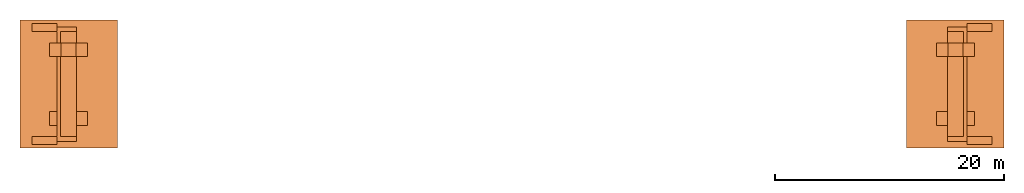
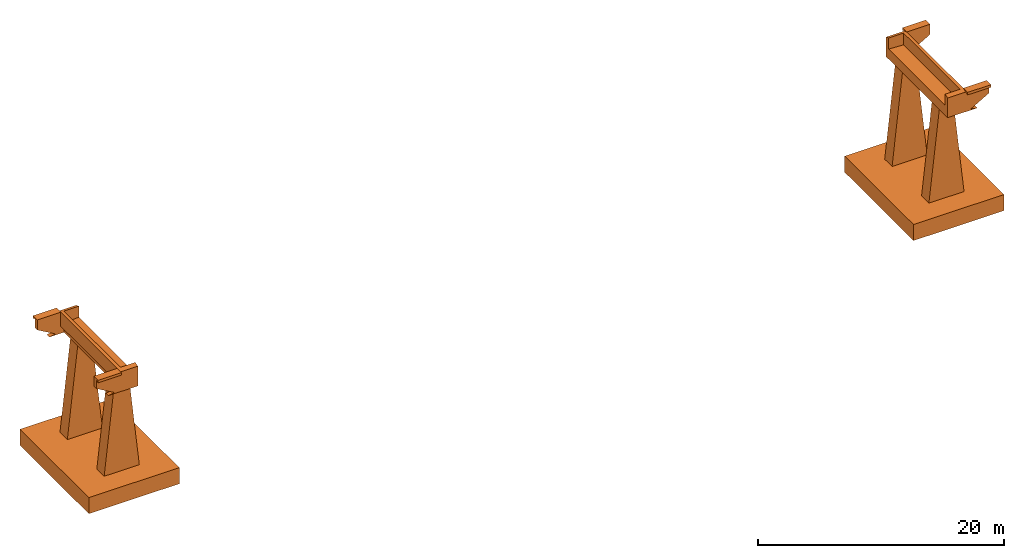
# One storey: 6 proxies.
"""IFC2X3 building model written with IfcOpenShell, lengths in metres."""

from ifc_helpers import new_model, entity, si_unit, converted_unit, derived_unit, direction, frame, origin, origin_2d_with_axis, place, context, subcontext, project, spatial, polyline, rectangle, outline, extrude, faceted_brep, source, transform, mapped, material, type_object, type_shapes, element, save


model = new_model("IFC2X3")

# Units and contexts
model_context = context("Model", 3, precision=1e-05, world=origin(), true_north=direction((6.12303176911189e-17, 1.0)))
body_context = subcontext(model_context, "Body", "Model", "MODEL_VIEW")
ifc_project = project(units=[si_unit("LENGTHUNIT", "METRE"), si_unit("AREAUNIT", "SQUARE_METRE"), si_unit("VOLUMEUNIT", "CUBIC_METRE"), converted_unit("PLANEANGLEUNIT", "DEGREE", entity("IfcRatioMeasure", 0.0174532925199433), si_unit("PLANEANGLEUNIT", "RADIAN"), dimensions=[0, 0, 0, 0, 0, 0, 0]), si_unit("MASSUNIT", "GRAM", prefix="KILO"), derived_unit("MASSDENSITYUNIT", [(si_unit("MASSUNIT", "GRAM", prefix="KILO"), 1), (si_unit("LENGTHUNIT", "METRE"), -3)]), si_unit("TIMEUNIT", "SECOND"), si_unit("FREQUENCYUNIT", "HERTZ"), si_unit("THERMODYNAMICTEMPERATUREUNIT", "DEGREE_CELSIUS"), derived_unit("THERMALTRANSMITTANCEUNIT", [(si_unit("MASSUNIT", "GRAM", prefix="KILO"), 1), (si_unit("THERMODYNAMICTEMPERATUREUNIT", "KELVIN"), -1), (si_unit("TIMEUNIT", "SECOND"), -3)]), derived_unit("VOLUMETRICFLOWRATEUNIT", [(si_unit("LENGTHUNIT", "METRE"), 3), (si_unit("TIMEUNIT", "SECOND"), -1)]), si_unit("ELECTRICCURRENTUNIT", "AMPERE"), si_unit("ELECTRICVOLTAGEUNIT", "VOLT"), si_unit("POWERUNIT", "WATT"), si_unit("FORCEUNIT", "NEWTON", prefix="KILO"), si_unit("ILLUMINANCEUNIT", "LUX"), si_unit("LUMINOUSFLUXUNIT", "LUMEN"), si_unit("LUMINOUSINTENSITYUNIT", "CANDELA"), derived_unit("USERDEFINED", [(si_unit("MASSUNIT", "GRAM", prefix="KILO"), -1), (si_unit("LENGTHUNIT", "METRE"), -2), (si_unit("TIMEUNIT", "SECOND"), 3), (si_unit("LUMINOUSFLUXUNIT", "LUMEN"), 1)]), derived_unit("LINEARVELOCITYUNIT", [(si_unit("LENGTHUNIT", "METRE"), 1), (si_unit("TIMEUNIT", "SECOND"), -1)]), si_unit("PRESSUREUNIT", "PASCAL"), derived_unit("USERDEFINED", [(si_unit("LENGTHUNIT", "METRE"), -2), (si_unit("MASSUNIT", "GRAM", prefix="KILO"), 1), (si_unit("TIMEUNIT", "SECOND"), -2)])], contexts=[model_context])

# Site, building, storey
site_placement = place(None, origin())
site = spatial("IfcSite", under=ifc_project, at=site_placement, CompositionType="ELEMENT")
building_placement = place(site_placement, origin())
building = spatial("IfcBuilding", under=site, at=building_placement, CompositionType="ELEMENT")
storey_placement = place(building_placement, origin())
storey = spatial("IfcBuildingStorey", under=building, at=storey_placement, Name="Nivel 1", CompositionType="ELEMENT", Elevation=0.0)

# Proxies
ifc_material = material(Name="Beton - C 30/37")
building_element_proxy_type_1 = type_object("IfcBuildingElementProxyType", PredefinedType="NOTDEFINED", material=ifc_material)
shared_shape_1 = source(origin(), body_context, "Body", "Brep", [
    faceted_brep([(-0.300000000000365, -5.29999999999995, 0.0), (-0.300000000000251, -4.59999999999999, 0.0), (-2.49999999999997, -4.59999999999995, 0.0), (-2.49999999999995, -5.29999999999994, 0.0), (-0.300000000000371, -5.0, -0.142857142857153), (-2.49999999999993, -5.0, -0.142857142857159), (-0.300000000000365, -5.29999999999995, -0.25), (-2.49999999999995, -5.29999999999995, -0.25)], [[[0, 1, 2, 3]], [[1, 4, 5, 2]], [[4, 6, 7, 5]], [[6, 0, 3, 7]], [[3, 2, 5, 7]], [[0, 6, 4, 1]]]),
    faceted_brep([(-0.300000000000286, 4.59999999999998, 0.0), (-0.300000000000293, 5.30000000000005, 0.0), (-2.49999999999993, 5.30000000000004, 0.0), (-2.49999999999978, 4.60000000000003, 0.0), (-0.300000000000293, 5.30000000000005, -0.25), (-2.49999999999993, 5.30000000000004, -0.25), (-0.300000000000413, 5.0, -0.142857142857126), (-2.49999999999983, 5.0, -0.142857142857127)], [[[0, 1, 2, 3]], [[1, 4, 5, 2]], [[4, 6, 7, 5]], [[6, 0, 3, 7]], [[2, 5, 7, 3]], [[1, 0, 6, 4]]]),
    faceted_brep([(-2.4999999999999, 4.60000000000004, 0.0), (1.39999999999949, 4.60000000000004, 0.0), (1.39999999999949, 5.0, -0.142857142857127), (-2.49999999999992, 5.0, -0.142857142857127), (1.39999999999949, 4.60000000000004, -1.09999999999999), (1.39999999999949, 4.60000000000004, -2.0), (1.39999999999949, 5.0, -2.0), (0.0, 4.60000000000004, -2.0), (-0.767949192431022, 4.60000000000004, -2.0), (-0.76794919243104, 5.0, -2.0), (-2.4999999999999, 4.60000000000004, -1.0), (-2.49999999999992, 5.0, -1.0)], [[[0, 1, 2, 3]], [[1, 4, 5, 6, 2]], [[5, 7, 8, 9, 6]], [[8, 10, 11, 9]], [[10, 0, 3, 11]], [[3, 2, 6, 9, 11]], [[0, 10, 8, 7, 5, 4, 1]]]),
    faceted_brep([(-2.49999999999998, -4.59999999999996, 0.0), (-2.49999999999998, -4.59999999999996, -1.0), (-2.49999999999997, -5.0, -1.0), (-2.49999999999997, -5.0, -0.142857142857159), (-0.767949192431102, -4.59999999999996, -2.0), (-0.767949192431093, -5.0, -2.0), (0.0, -4.59999999999997, -2.0), (1.39999999999943, -4.59999999999999, -2.0), (1.39999999999943, -5.0, -2.0), (1.39999999999943, -4.59999999999999, -1.10000000000002), (1.39999999999943, -4.6, 0.0), (1.39999999999943, -5.0, -0.142857142857159)], [[[0, 1, 2, 3]], [[1, 4, 5, 2]], [[4, 6, 7, 8, 5]], [[7, 9, 10, 11, 8]], [[10, 0, 3, 11]], [[3, 2, 5, 8, 11]], [[0, 10, 9, 7, 6, 4, 1]]]),
    faceted_brep([(-1.36794919243106, 5.0, -2.10000000000002), (-1.36794919243098, 4.60000000000003, -2.10000000000001), (-0.867949192430952, 4.60000000000002, -2.0), (-0.867949192430983, 5.0, -2.0), (0.0, 4.60000000000001, -2.10000000000001), (0.0, 4.6, -2.0), (0.0, -4.59999999999997, -2.09999999999998), (0.0, -4.6, -2.0), (-1.3679491924313, -4.60000000000007, -2.09999999999998), (-0.867949192431095, -4.59999999999997, -2.0), (-1.36794919243115, -5.0, -2.09999999999997), (-0.867949192431087, -5.0, -2.0), (1.39999999999947, -5.0, -2.09999999999998), (1.39999999999851, -5.0, -2.0), (1.3999999999995, 5.0, -2.10000000000001), (1.3999999999986, 5.0, -2.0)], [[[0, 1, 2, 3]], [[1, 4, 5, 2]], [[4, 6, 7, 5]], [[6, 8, 9, 7]], [[8, 10, 11, 9]], [[10, 12, 13, 11]], [[12, 14, 15, 13]], [[14, 0, 3, 15]], [[11, 13, 15, 3, 2, 5, 7, 9]], [[0, 14, 12, 10, 8, 6, 4, 1]]]),
    faceted_brep([(-0.300000000000678, -4.59999999999995, 0.0), (0.0, -4.59999999999994, 0.0), (0.0, 4.59999999999998, 0.0), (-0.300000000000657, 4.60000000000004, 0.0), (0.0, -4.59999999999994, -1.17000000000002), (0.0, 4.60000000000005, -1.16999999999999), (1.3999999999988, -4.59999999999998, -1.10000000000001), (1.39999999999879, 4.60000000000003, -1.09999999999999), (1.3999999999988, -4.59999999999999, -2.0), (1.39999999999879, 4.60000000000003, -2.0), (0.0, -4.59999999999994, -2.0), (0.0, 4.60000000000005, -2.0), (0.0, -4.59999999999994, -1.70000000000002), (0.0, 4.60000000000005, -1.69999999999999), (-0.300000000000688, -4.59999999999994, -1.40000000000002), (-0.300000000000657, 4.60000000000004, -1.39999999999999)], [[[0, 1, 2, 3]], [[1, 4, 5, 2]], [[4, 6, 7, 5]], [[6, 8, 9, 7]], [[8, 10, 11, 9]], [[10, 12, 13, 11]], [[12, 14, 15, 13]], [[14, 0, 3, 15]], [[3, 2, 5, 7, 9, 11, 13, 15]], [[0, 14, 12, 10, 8, 6, 4, 1]]]),
])
type_shapes(building_element_proxy_type_1, [shared_shape_1])
proxy_1_placement = place(storey_placement, frame((-0.15, 0.0, 0.0120356234096692)))
element("IfcBuildingElementProxy", 1, at=proxy_1_placement, inside=storey, type_object=building_element_proxy_type_1, material=ifc_material, context=body_context, shape_type="MappedRepresentation", body=[
    mapped(shared_shape_1, transform((0.0, 0.0, 0.0), scale=1.0)),
])
proxy_2_placement = place(storey_placement, frame((78.75, 0.0, 0.0120356234096693), z_axis=(0.0, 0.0, 1.0), x_axis=(-1.0, 0.0, 0.0)))
element("IfcBuildingElementProxy", 2, at=proxy_2_placement, inside=storey, type_object=building_element_proxy_type_1, material=ifc_material, context=body_context, shape_type="MappedRepresentation", body=[
    mapped(shared_shape_1, transform((0.0, 0.0, 0.0), scale=1.0)),
])
building_element_proxy_type_2 = type_object("IfcBuildingElementProxyType", PredefinedType="NOTDEFINED")
shared_shape_2 = source(origin(), body_context, "Body", "SweptSolid", [
    extrude(outline(polyline([(-4.75136217838739, -1.14326613252988), (4.50282606262003, -1.14326613252988), (4.64330299761897, 0.149121669460419), (-4.39476688185161, 2.13741059559933), (-4.75136217838739, -1.14326613252988)])), frame((0.0, -0.6, -6.5), z_axis=(0.0, 1.0, 0.0), x_axis=(0.108059180768419, 0.0, 0.994144463069457)), (0.0, 0.0, 1.0), 1.2),
    extrude(rectangle(XDim=8.5, YDim=11.2, at=origin_2d_with_axis()), frame((0.0, 3.0, -12.7)), (0.0, 0.0, 1.0), 1.6),
])
type_shapes(building_element_proxy_type_2, [shared_shape_2])
for number, where in (
    (3, (0.55, -3.0, 0.0120356234096692)),
    (4, (78.05, -3.0, 0.0120356234096693)),
):
    element("IfcBuildingElementProxy", number, at=place(storey_placement, frame(where)), inside=storey, type_object=building_element_proxy_type_2, context=body_context, shape_type="MappedRepresentation", body=[
        mapped(shared_shape_2, transform((0.0, 0.0, 0.0), scale=1.0)),
    ])
building_element_proxy_type_3 = type_object("IfcBuildingElementProxyType", PredefinedType="NOTDEFINED")
shared_shape_3 = source(origin(), body_context, "Body", "SweptSolid", [
    extrude(outline(polyline([(-4.75136217838739, -1.14326613252988), (4.50282606262003, -1.14326613252988), (4.64330299761897, 0.149121669460419), (-4.39476688185161, 2.13741059559933), (-4.75136217838739, -1.14326613252988)])), frame((0.0, -0.6, -6.5), z_axis=(0.0, 1.0, 0.0), x_axis=(0.108059180768419, 0.0, 0.994144463069457)), (0.0, 0.0, 1.0), 1.2),
])
type_shapes(building_element_proxy_type_3, [shared_shape_3])
for number, where in (
    (5, (0.55, 3.0, 0.0120356234096692)),
    (6, (78.05, 3.0, 0.0120356234096693)),
):
    element("IfcBuildingElementProxy", number, at=place(storey_placement, frame(where)), inside=storey, type_object=building_element_proxy_type_3, context=body_context, shape_type="MappedRepresentation", body=[
        mapped(shared_shape_3, transform((0.0, 0.0, 0.0), scale=1.0)),
    ])

save(model, "model.ifc")
